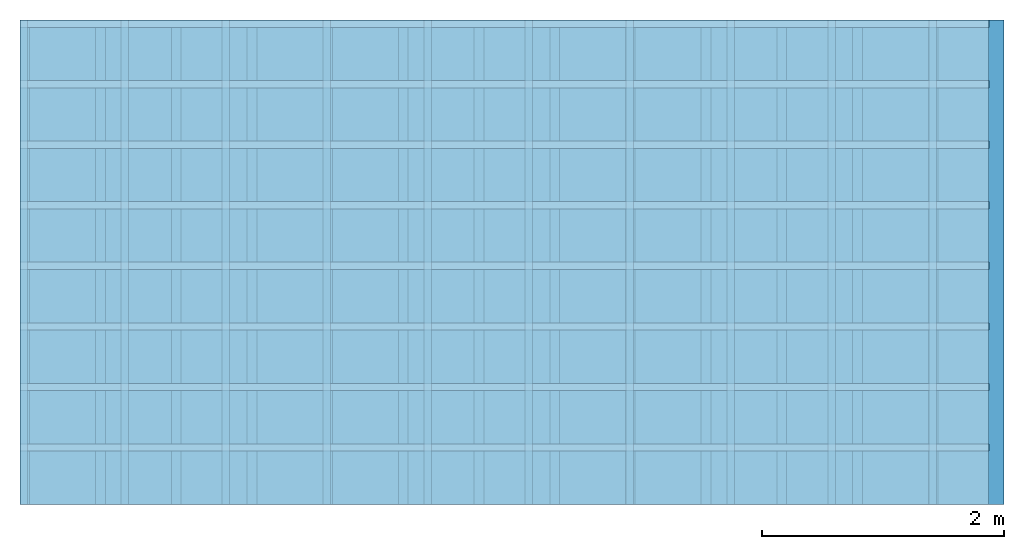
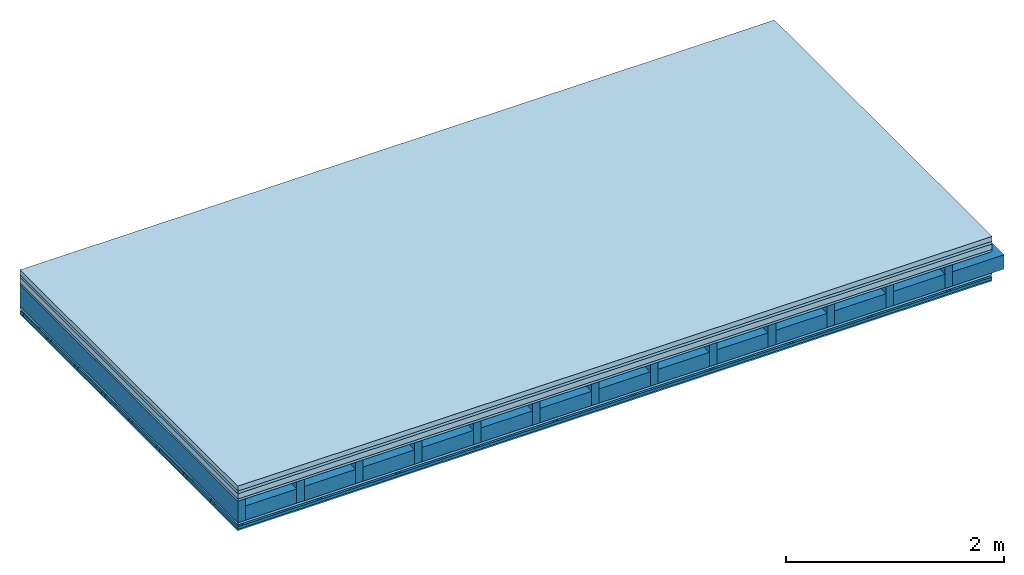
# One storey: 6 plates, 5 members, 1 element without a shape of its own.
"""IFC4 building model written with IfcOpenShell, lengths in metres."""

from ifc_helpers import new_model, si_unit, derived_unit, direction, frame, frame_2d, origin, origin_with_axes, place, context, project, spatial, polyline, rectangle, outline, extrude, material, layer, layer_set, type_object, element, aggregate, save


model = new_model("IFC4")

# Units and contexts
plan_context = context("Plan", 3, precision=1e-05, world=origin(), true_north=direction((0.0, 1.0)))
model_context = context("Model", 3, precision=1e-05, world=origin(), true_north=direction((0.0, 1.0)))
ifc_project = project(units=[si_unit("LENGTHUNIT", "METRE"), derived_unit("SOUNDPRESSUREUNIT", [(si_unit("PRESSUREUNIT", "PASCAL", prefix="MICRO"), 0)]), si_unit("ENERGYUNIT", "JOULE", prefix="MEGA"), si_unit("MASSUNIT", "GRAM", prefix="KILO"), derived_unit("THERMALTRANSMITTANCEUNIT", [(si_unit("POWERUNIT", "WATT"), 1), (si_unit("AREAUNIT", "SQUARE_METRE"), -1), (si_unit("THERMODYNAMICTEMPERATUREUNIT", "KELVIN"), -1)]), derived_unit("AREADENSITYUNIT", [(si_unit("MASSUNIT", "GRAM", prefix="KILO"), 1), (si_unit("AREAUNIT", "SQUARE_METRE"), -1)]), derived_unit("USERDEFINED", [(si_unit("ENERGYUNIT", "JOULE", prefix="MEGA"), 1), (si_unit("AREAUNIT", "SQUARE_METRE"), -1)])], contexts=[plan_context, model_context])

# Site, building, storey
site = spatial("IfcSite", under=ifc_project)
building_placement = place(None, origin())
building = spatial("IfcBuilding", under=site, at=building_placement)
storey_placement = place(building_placement, origin())
storey = spatial("IfcBuildingStorey", under=building, at=storey_placement)

# Slab, members, plates
ifc_material_1 = material(Category="04.005")
ifc_layer_1 = layer(ifc_material_1, 0.055, Name="On-material")
ifc_material_2 = material()
ifc_layer_2 = layer(ifc_material_2, 0.03, Name="Impact sound insulation")
ifc_material_3 = material(Name="Cement panels, glued on sub-floor", Category="02.007")
ifc_layer_3 = layer(ifc_material_3, 0.06, Name="on Supporting structure")
ifc_material_4 = material(Category="07.001")
ifc_layer_4 = layer(ifc_material_4, 0.025, Name="Sub-floor")
ifc_material_5 = material(Name="Rigid, of the art")
ifc_layer_5 = layer(ifc_material_5, 0.0, Name="Bond")
ifc_layer_6 = layer(None, 0.24, Name="Supporting structure")
ifc_layer_7 = layer(ifc_material_5, 0.0, Name="Bond")
ifc_layer_8 = layer(ifc_material_4, 0.025, Name="Lower layer 1")
ifc_layer_9 = layer(None, 0.02, Name="Coupling")
ifc_layer_10 = layer(None, 0.03, Name="Battens / profiles")
ifc_material_6 = material(Category="03.007")
ifc_layer_11 = layer(ifc_material_6, 0.015, Name="Ceiling covering 1st layer")
ifc_material_7 = material(Name="Glued joints")
ifc_layer_12 = layer(ifc_material_7, 0.0, Name="Surface / treatment")
ifc_layer_set = layer_set([ifc_layer_1, ifc_layer_2, ifc_layer_3, ifc_layer_4, ifc_layer_5, ifc_layer_6, ifc_layer_7, ifc_layer_8, ifc_layer_9, ifc_layer_10, ifc_layer_11, ifc_layer_12])
slab_type = type_object("IfcSlabType", Name="A0485", PredefinedType="NOTDEFINED", material=ifc_layer_set)
slab_placement = place(None, frame((0.0, 0.0, 0.0), z_axis=(0.0, 0.0, -1.0), x_axis=(1.0, 0.0, 0.0)))
slab = element("IfcSlab", 1, at=slab_placement, inside=storey, type_object=slab_type, material=ifc_layer_set, Name="Slab #1")
ifc_material_8 = material()
member_1_placement = place(slab_placement, origin())
member_1 = element("IfcMember", 2, at=member_1_placement, material=ifc_material_8, Name="Supporting structure", context=plan_context, shape_type="SweptSolid", body=[
    extrude(rectangle(XDim=0.08, YDim=0.24, at=frame_2d((0.04, 0.12), x_axis=(1.0, 0.0))), frame((0.0, 4.0, 0.17), z_axis=(0.0, -1.0, 0.0), x_axis=(1.0, 0.0, 0.0)), (0.0, 0.0, 1.0), 4.0),
    extrude(rectangle(XDim=0.08, YDim=0.24, at=frame_2d((0.04, 0.12), x_axis=(1.0, 0.0))), frame((0.625, 4.0, 0.17), z_axis=(0.0, -1.0, 0.0), x_axis=(1.0, 0.0, 0.0)), (0.0, 0.0, 1.0), 4.0),
    extrude(rectangle(XDim=0.08, YDim=0.24, at=frame_2d((0.04, 0.12), x_axis=(1.0, 0.0))), frame((1.25, 4.0, 0.17), z_axis=(0.0, -1.0, 0.0), x_axis=(1.0, 0.0, 0.0)), (0.0, 0.0, 1.0), 4.0),
    extrude(rectangle(XDim=0.08, YDim=0.24, at=frame_2d((0.04, 0.12), x_axis=(1.0, 0.0))), frame((1.875, 4.0, 0.17), z_axis=(0.0, -1.0, 0.0), x_axis=(1.0, 0.0, 0.0)), (0.0, 0.0, 1.0), 4.0),
    extrude(rectangle(XDim=0.08, YDim=0.24, at=frame_2d((0.04, 0.12), x_axis=(1.0, 0.0))), frame((2.5, 4.0, 0.17), z_axis=(0.0, -1.0, 0.0), x_axis=(1.0, 0.0, 0.0)), (0.0, 0.0, 1.0), 4.0),
    extrude(rectangle(XDim=0.08, YDim=0.24, at=frame_2d((0.04, 0.12), x_axis=(1.0, 0.0))), frame((3.125, 4.0, 0.17), z_axis=(0.0, -1.0, 0.0), x_axis=(1.0, 0.0, 0.0)), (0.0, 0.0, 1.0), 4.0),
    extrude(rectangle(XDim=0.08, YDim=0.24, at=frame_2d((0.04, 0.12), x_axis=(1.0, 0.0))), frame((3.75, 4.0, 0.17), z_axis=(0.0, -1.0, 0.0), x_axis=(1.0, 0.0, 0.0)), (0.0, 0.0, 1.0), 4.0),
    extrude(rectangle(XDim=0.08, YDim=0.24, at=frame_2d((0.04, 0.12), x_axis=(1.0, 0.0))), frame((4.375, 4.0, 0.17), z_axis=(0.0, -1.0, 0.0), x_axis=(1.0, 0.0, 0.0)), (0.0, 0.0, 1.0), 4.0),
    extrude(rectangle(XDim=0.08, YDim=0.24, at=frame_2d((0.04, 0.12), x_axis=(1.0, 0.0))), frame((5.0, 4.0, 0.17), z_axis=(0.0, -1.0, 0.0), x_axis=(1.0, 0.0, 0.0)), (0.0, 0.0, 1.0), 4.0),
    extrude(rectangle(XDim=0.08, YDim=0.24, at=frame_2d((0.04, 0.12), x_axis=(1.0, 0.0))), frame((5.625, 4.0, 0.17), z_axis=(0.0, -1.0, 0.0), x_axis=(1.0, 0.0, 0.0)), (0.0, 0.0, 1.0), 4.0),
    extrude(rectangle(XDim=0.08, YDim=0.24, at=frame_2d((0.04, 0.12), x_axis=(1.0, 0.0))), frame((6.25, 4.0, 0.17), z_axis=(0.0, -1.0, 0.0), x_axis=(1.0, 0.0, 0.0)), (0.0, 0.0, 1.0), 4.0),
    extrude(rectangle(XDim=0.08, YDim=0.24, at=frame_2d((0.04, 0.12), x_axis=(1.0, 0.0))), frame((6.875, 4.0, 0.17), z_axis=(0.0, -1.0, 0.0), x_axis=(1.0, 0.0, 0.0)), (0.0, 0.0, 1.0), 4.0),
    extrude(rectangle(XDim=0.08, YDim=0.24, at=frame_2d((0.04, 0.12), x_axis=(1.0, 0.0))), frame((7.5, 4.0, 0.17), z_axis=(0.0, -1.0, 0.0), x_axis=(1.0, 0.0, 0.0)), (0.0, 0.0, 1.0), 4.0),
])
ifc_material_9 = material()
member_2_placement = place(slab_placement, origin())
member_2 = element("IfcMember", 3, at=member_2_placement, material=ifc_material_9, Name="Cavity", context=plan_context, shape_type="SweptSolid", body=[
    extrude(rectangle(XDim=0.545, YDim=0.16, at=frame_2d((0.2725, 0.08), x_axis=(1.0, 0.0))), frame((0.08, 4.0, 0.25), z_axis=(0.0, -1.0, 0.0), x_axis=(1.0, 0.0, 0.0)), (0.0, 0.0, 1.0), 4.0),
    extrude(rectangle(XDim=0.545, YDim=0.16, at=frame_2d((0.2725, 0.08), x_axis=(1.0, 0.0))), frame((0.705, 4.0, 0.25), z_axis=(0.0, -1.0, 0.0), x_axis=(1.0, 0.0, 0.0)), (0.0, 0.0, 1.0), 4.0),
    extrude(rectangle(XDim=0.545, YDim=0.16, at=frame_2d((0.2725, 0.08), x_axis=(1.0, 0.0))), frame((1.33, 4.0, 0.25), z_axis=(0.0, -1.0, 0.0), x_axis=(1.0, 0.0, 0.0)), (0.0, 0.0, 1.0), 4.0),
    extrude(rectangle(XDim=0.545, YDim=0.16, at=frame_2d((0.2725, 0.08), x_axis=(1.0, 0.0))), frame((1.955, 4.0, 0.25), z_axis=(0.0, -1.0, 0.0), x_axis=(1.0, 0.0, 0.0)), (0.0, 0.0, 1.0), 4.0),
    extrude(rectangle(XDim=0.545, YDim=0.16, at=frame_2d((0.2725, 0.08), x_axis=(1.0, 0.0))), frame((2.58, 4.0, 0.25), z_axis=(0.0, -1.0, 0.0), x_axis=(1.0, 0.0, 0.0)), (0.0, 0.0, 1.0), 4.0),
    extrude(rectangle(XDim=0.545, YDim=0.16, at=frame_2d((0.2725, 0.08), x_axis=(1.0, 0.0))), frame((3.205, 4.0, 0.25), z_axis=(0.0, -1.0, 0.0), x_axis=(1.0, 0.0, 0.0)), (0.0, 0.0, 1.0), 4.0),
    extrude(rectangle(XDim=0.545, YDim=0.16, at=frame_2d((0.2725, 0.08), x_axis=(1.0, 0.0))), frame((3.83, 4.0, 0.25), z_axis=(0.0, -1.0, 0.0), x_axis=(1.0, 0.0, 0.0)), (0.0, 0.0, 1.0), 4.0),
    extrude(rectangle(XDim=0.545, YDim=0.16, at=frame_2d((0.2725, 0.08), x_axis=(1.0, 0.0))), frame((4.455, 4.0, 0.25), z_axis=(0.0, -1.0, 0.0), x_axis=(1.0, 0.0, 0.0)), (0.0, 0.0, 1.0), 4.0),
    extrude(rectangle(XDim=0.545, YDim=0.16, at=frame_2d((0.2725, 0.08), x_axis=(1.0, 0.0))), frame((5.08, 4.0, 0.25), z_axis=(0.0, -1.0, 0.0), x_axis=(1.0, 0.0, 0.0)), (0.0, 0.0, 1.0), 4.0),
    extrude(rectangle(XDim=0.545, YDim=0.16, at=frame_2d((0.2725, 0.08), x_axis=(1.0, 0.0))), frame((5.705, 4.0, 0.25), z_axis=(0.0, -1.0, 0.0), x_axis=(1.0, 0.0, 0.0)), (0.0, 0.0, 1.0), 4.0),
    extrude(rectangle(XDim=0.545, YDim=0.16, at=frame_2d((0.2725, 0.08), x_axis=(1.0, 0.0))), frame((6.33, 4.0, 0.25), z_axis=(0.0, -1.0, 0.0), x_axis=(1.0, 0.0, 0.0)), (0.0, 0.0, 1.0), 4.0),
    extrude(rectangle(XDim=0.545, YDim=0.16, at=frame_2d((0.2725, 0.08), x_axis=(1.0, 0.0))), frame((6.955, 4.0, 0.25), z_axis=(0.0, -1.0, 0.0), x_axis=(1.0, 0.0, 0.0)), (0.0, 0.0, 1.0), 4.0),
    extrude(rectangle(XDim=0.545, YDim=0.16, at=frame_2d((0.2725, 0.08), x_axis=(1.0, 0.0))), frame((7.58, 4.0, 0.25), z_axis=(0.0, -1.0, 0.0), x_axis=(1.0, 0.0, 0.0)), (0.0, 0.0, 1.0), 4.0),
])
ifc_material_10 = material()
member_3_placement = place(slab_placement, origin())
member_3 = element("IfcMember", 4, at=member_3_placement, material=ifc_material_10, Name="Coupling", context=plan_context, shape_type="SweptSolid", body=[
    extrude(outline(polyline([(0.0, 0.0), (0.06, 0.0), (0.04, 0.02), (0.02, 0.02), (0.0, 0.0)])), frame((0.0, 4.0, 0.435), z_axis=(0.0, -1.0, 0.0), x_axis=(1.0, 0.0, 0.0)), (0.0, 0.0, 1.0), 4.0),
    extrude(outline(polyline([(0.0, 0.0), (0.06, 0.0), (0.04, 0.02), (0.02, 0.02), (0.0, 0.0)])), frame((0.834, 4.0, 0.435), z_axis=(0.0, -1.0, 0.0), x_axis=(1.0, 0.0, 0.0)), (0.0, 0.0, 1.0), 4.0),
    extrude(outline(polyline([(0.0, 0.0), (0.06, 0.0), (0.04, 0.02), (0.02, 0.02), (0.0, 0.0)])), frame((1.668, 4.0, 0.435), z_axis=(0.0, -1.0, 0.0), x_axis=(1.0, 0.0, 0.0)), (0.0, 0.0, 1.0), 4.0),
    extrude(outline(polyline([(0.0, 0.0), (0.06, 0.0), (0.04, 0.02), (0.02, 0.02), (0.0, 0.0)])), frame((2.502, 4.0, 0.435), z_axis=(0.0, -1.0, 0.0), x_axis=(1.0, 0.0, 0.0)), (0.0, 0.0, 1.0), 4.0),
    extrude(outline(polyline([(0.0, 0.0), (0.06, 0.0), (0.04, 0.02), (0.02, 0.02), (0.0, 0.0)])), frame((3.336, 4.0, 0.435), z_axis=(0.0, -1.0, 0.0), x_axis=(1.0, 0.0, 0.0)), (0.0, 0.0, 1.0), 4.0),
    extrude(outline(polyline([(0.0, 0.0), (0.06, 0.0), (0.04, 0.02), (0.02, 0.02), (0.0, 0.0)])), frame((4.17, 4.0, 0.435), z_axis=(0.0, -1.0, 0.0), x_axis=(1.0, 0.0, 0.0)), (0.0, 0.0, 1.0), 4.0),
    extrude(outline(polyline([(0.0, 0.0), (0.06, 0.0), (0.04, 0.02), (0.02, 0.02), (0.0, 0.0)])), frame((5.004, 4.0, 0.435), z_axis=(0.0, -1.0, 0.0), x_axis=(1.0, 0.0, 0.0)), (0.0, 0.0, 1.0), 4.0),
    extrude(outline(polyline([(0.0, 0.0), (0.06, 0.0), (0.04, 0.02), (0.02, 0.02), (0.0, 0.0)])), frame((5.838, 4.0, 0.435), z_axis=(0.0, -1.0, 0.0), x_axis=(1.0, 0.0, 0.0)), (0.0, 0.0, 1.0), 4.0),
    extrude(outline(polyline([(0.0, 0.0), (0.06, 0.0), (0.04, 0.02), (0.02, 0.02), (0.0, 0.0)])), frame((6.672, 4.0, 0.435), z_axis=(0.0, -1.0, 0.0), x_axis=(1.0, 0.0, 0.0)), (0.0, 0.0, 1.0), 4.0),
    extrude(outline(polyline([(0.0, 0.0), (0.06, 0.0), (0.04, 0.02), (0.02, 0.02), (0.0, 0.0)])), frame((7.506, 4.0, 0.435), z_axis=(0.0, -1.0, 0.0), x_axis=(1.0, 0.0, 0.0)), (0.0, 0.0, 1.0), 4.0),
])
ifc_material_11 = material()
member_4_placement = place(slab_placement, origin())
member_4 = element("IfcMember", 5, at=member_4_placement, material=ifc_material_11, Name="Battens / profiles", context=plan_context, shape_type="SweptSolid", body=[
    extrude(rectangle(XDim=0.06, YDim=0.03, at=frame_2d((0.03, 0.015), x_axis=(1.0, 0.0))), frame((0.0, 0.0, 0.455), z_axis=(1.0, 0.0, 0.0), x_axis=(0.0, 1.0, 0.0)), (0.0, 0.0, 1.0), 8.0),
    extrude(rectangle(XDim=0.06, YDim=0.03, at=frame_2d((0.03, 0.015), x_axis=(1.0, 0.0))), frame((0.0, 0.5, 0.455), z_axis=(1.0, 0.0, 0.0), x_axis=(0.0, 1.0, 0.0)), (0.0, 0.0, 1.0), 8.0),
    extrude(rectangle(XDim=0.06, YDim=0.03, at=frame_2d((0.03, 0.015), x_axis=(1.0, 0.0))), frame((0.0, 1.0, 0.455), z_axis=(1.0, 0.0, 0.0), x_axis=(0.0, 1.0, 0.0)), (0.0, 0.0, 1.0), 8.0),
    extrude(rectangle(XDim=0.06, YDim=0.03, at=frame_2d((0.03, 0.015), x_axis=(1.0, 0.0))), frame((0.0, 1.5, 0.455), z_axis=(1.0, 0.0, 0.0), x_axis=(0.0, 1.0, 0.0)), (0.0, 0.0, 1.0), 8.0),
    extrude(rectangle(XDim=0.06, YDim=0.03, at=frame_2d((0.03, 0.015), x_axis=(1.0, 0.0))), frame((0.0, 2.0, 0.455), z_axis=(1.0, 0.0, 0.0), x_axis=(0.0, 1.0, 0.0)), (0.0, 0.0, 1.0), 8.0),
    extrude(rectangle(XDim=0.06, YDim=0.03, at=frame_2d((0.03, 0.015), x_axis=(1.0, 0.0))), frame((0.0, 2.5, 0.455), z_axis=(1.0, 0.0, 0.0), x_axis=(0.0, 1.0, 0.0)), (0.0, 0.0, 1.0), 8.0),
    extrude(rectangle(XDim=0.06, YDim=0.03, at=frame_2d((0.03, 0.015), x_axis=(1.0, 0.0))), frame((0.0, 3.0, 0.455), z_axis=(1.0, 0.0, 0.0), x_axis=(0.0, 1.0, 0.0)), (0.0, 0.0, 1.0), 8.0),
    extrude(rectangle(XDim=0.06, YDim=0.03, at=frame_2d((0.03, 0.015), x_axis=(1.0, 0.0))), frame((0.0, 3.5, 0.455), z_axis=(1.0, 0.0, 0.0), x_axis=(0.0, 1.0, 0.0)), (0.0, 0.0, 1.0), 8.0),
])
member_5_placement = place(slab_placement, origin())
member_5 = element("IfcMember", 6, at=member_5_placement, material=ifc_material_9, Name="Cavity", context=plan_context, shape_type="SweptSolid", body=[
    extrude(rectangle(XDim=0.44, YDim=0.03, at=frame_2d((0.22, 0.015), x_axis=(1.0, 0.0))), frame((0.0, 0.06, 0.455), z_axis=(1.0, 0.0, 0.0), x_axis=(0.0, 1.0, 0.0)), (0.0, 0.0, 1.0), 8.0),
    extrude(rectangle(XDim=0.44, YDim=0.03, at=frame_2d((0.22, 0.015), x_axis=(1.0, 0.0))), frame((0.0, 0.56, 0.455), z_axis=(1.0, 0.0, 0.0), x_axis=(0.0, 1.0, 0.0)), (0.0, 0.0, 1.0), 8.0),
    extrude(rectangle(XDim=0.44, YDim=0.03, at=frame_2d((0.22, 0.015), x_axis=(1.0, 0.0))), frame((0.0, 1.06, 0.455), z_axis=(1.0, 0.0, 0.0), x_axis=(0.0, 1.0, 0.0)), (0.0, 0.0, 1.0), 8.0),
    extrude(rectangle(XDim=0.44, YDim=0.03, at=frame_2d((0.22, 0.015), x_axis=(1.0, 0.0))), frame((0.0, 1.56, 0.455), z_axis=(1.0, 0.0, 0.0), x_axis=(0.0, 1.0, 0.0)), (0.0, 0.0, 1.0), 8.0),
    extrude(rectangle(XDim=0.44, YDim=0.03, at=frame_2d((0.22, 0.015), x_axis=(1.0, 0.0))), frame((0.0, 2.06, 0.455), z_axis=(1.0, 0.0, 0.0), x_axis=(0.0, 1.0, 0.0)), (0.0, 0.0, 1.0), 8.0),
    extrude(rectangle(XDim=0.44, YDim=0.03, at=frame_2d((0.22, 0.015), x_axis=(1.0, 0.0))), frame((0.0, 2.56, 0.455), z_axis=(1.0, 0.0, 0.0), x_axis=(0.0, 1.0, 0.0)), (0.0, 0.0, 1.0), 8.0),
    extrude(rectangle(XDim=0.44, YDim=0.03, at=frame_2d((0.22, 0.015), x_axis=(1.0, 0.0))), frame((0.0, 3.06, 0.455), z_axis=(1.0, 0.0, 0.0), x_axis=(0.0, 1.0, 0.0)), (0.0, 0.0, 1.0), 8.0),
    extrude(rectangle(XDim=0.44, YDim=0.03, at=frame_2d((0.22, 0.015), x_axis=(1.0, 0.0))), frame((0.0, 3.56, 0.455), z_axis=(1.0, 0.0, 0.0), x_axis=(0.0, 1.0, 0.0)), (0.0, 0.0, 1.0), 8.0),
])
plate_1_placement = place(slab_placement, origin())
plate_1 = element("IfcPlate", 7, at=plate_1_placement, material=ifc_material_1, Name="On-material", context=plan_context, shape_type="SweptSolid", body=[
    extrude(rectangle(XDim=8.0, YDim=4.0, at=frame_2d((4.0, 2.0), x_axis=(1.0, 0.0))), origin_with_axes(), (0.0, 0.0, 1.0), 0.055),
])
plate_2_placement = place(slab_placement, origin())
plate_2 = element("IfcPlate", 8, at=plate_2_placement, material=ifc_material_2, Name="Impact sound insulation", context=plan_context, shape_type="SweptSolid", body=[
    extrude(rectangle(XDim=8.0, YDim=4.0, at=frame_2d((4.0, 2.0), x_axis=(1.0, 0.0))), frame((0.0, 0.0, 0.055), z_axis=(0.0, 0.0, 1.0), x_axis=(1.0, 0.0, 0.0)), (0.0, 0.0, 1.0), 0.03),
])
plate_3_placement = place(slab_placement, origin())
plate_3 = element("IfcPlate", 9, at=plate_3_placement, material=ifc_material_3, Name="on Supporting structure", context=plan_context, shape_type="SweptSolid", body=[
    extrude(rectangle(XDim=8.0, YDim=4.0, at=frame_2d((4.0, 2.0), x_axis=(1.0, 0.0))), frame((0.0, 0.0, 0.085), z_axis=(0.0, 0.0, 1.0), x_axis=(1.0, 0.0, 0.0)), (0.0, 0.0, 1.0), 0.06),
])
plate_4_placement = place(slab_placement, origin())
plate_4 = element("IfcPlate", 10, at=plate_4_placement, material=ifc_material_4, Name="Sub-floor", context=plan_context, shape_type="SweptSolid", body=[
    extrude(rectangle(XDim=8.0, YDim=4.0, at=frame_2d((4.0, 2.0), x_axis=(1.0, 0.0))), frame((0.0, 0.0, 0.145), z_axis=(0.0, 0.0, 1.0), x_axis=(1.0, 0.0, 0.0)), (0.0, 0.0, 1.0), 0.025),
])
plate_5_placement = place(slab_placement, origin())
plate_5 = element("IfcPlate", 11, at=plate_5_placement, material=ifc_material_4, Name="Lower layer 1", context=plan_context, shape_type="SweptSolid", body=[
    extrude(rectangle(XDim=8.0, YDim=4.0, at=frame_2d((4.0, 2.0), x_axis=(1.0, 0.0))), frame((0.0, 0.0, 0.41), z_axis=(0.0, 0.0, 1.0), x_axis=(1.0, 0.0, 0.0)), (0.0, 0.0, 1.0), 0.025),
])
plate_6_placement = place(slab_placement, origin())
plate_6 = element("IfcPlate", 12, at=plate_6_placement, material=ifc_material_6, Name="Ceiling covering 1st layer", context=plan_context, shape_type="SweptSolid", body=[
    extrude(rectangle(XDim=8.0, YDim=4.0, at=frame_2d((4.0, 2.0), x_axis=(1.0, 0.0))), frame((0.0, 0.0, 0.485), z_axis=(0.0, 0.0, 1.0), x_axis=(1.0, 0.0, 0.0)), (0.0, 0.0, 1.0), 0.015),
])
aggregate(slab, [plate_1, plate_2, plate_3, plate_4, member_1, member_2, plate_5, member_3, member_4, member_5, plate_6])

save(model, "model.ifc")
